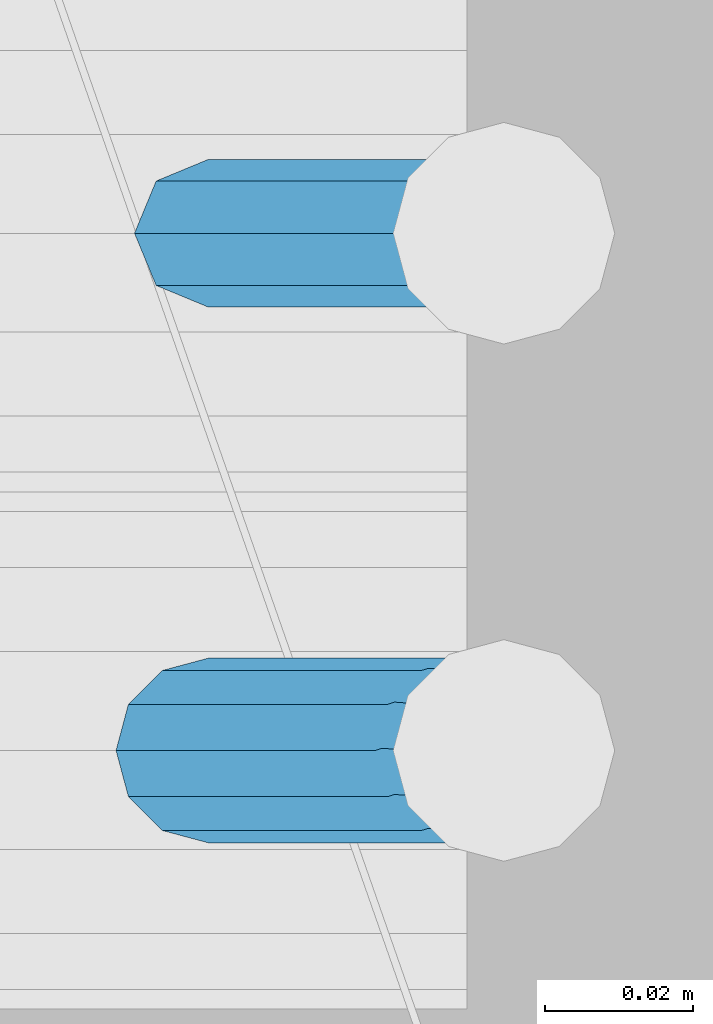
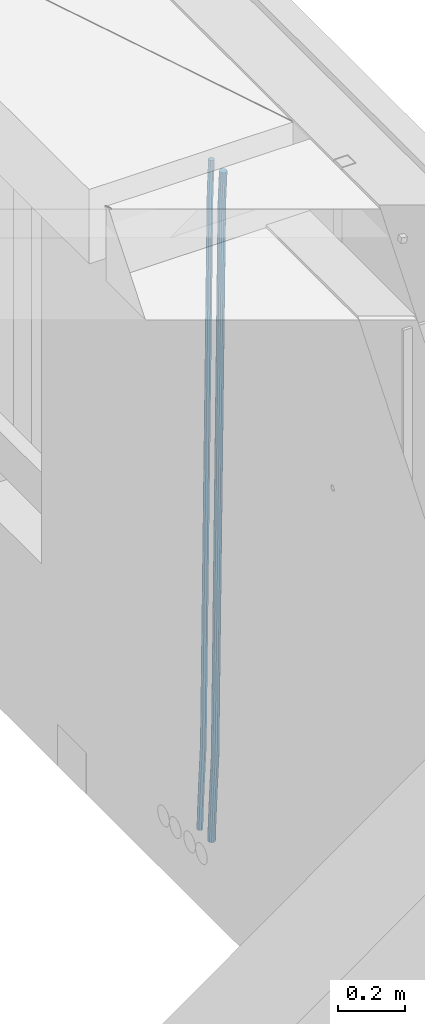
# One storey, part 134 of 350: 2 beams, 1 element without a shape of its own.
"""IFC2X3 building model written with IfcOpenShell, lengths in millimetres."""

from ifc_helpers import new_model, si_unit, frame, origin_with_axes, place, context, subcontext, project, spatial, faceted_brep, material, type_object, element, aggregate, save


model = new_model("IFC2X3")

# Units and contexts
model_context = context("Model", 3, precision=1e-05, world=origin_with_axes())
body_context = subcontext(model_context, "Body", "Model", "MODEL_VIEW")
ifc_project = project(units=[si_unit("LENGTHUNIT", "METRE", prefix="MILLI"), si_unit("AREAUNIT", "SQUARE_METRE"), si_unit("VOLUMEUNIT", "CUBIC_METRE"), si_unit("MASSUNIT", "GRAM", prefix="KILO"), si_unit("TIMEUNIT", "SECOND"), si_unit("PLANEANGLEUNIT", "RADIAN"), si_unit("SOLIDANGLEUNIT", "STERADIAN"), si_unit("THERMODYNAMICTEMPERATUREUNIT", "DEGREE_CELSIUS"), si_unit("LUMINOUSINTENSITYUNIT", "LUMEN")], contexts=[model_context])

# Site, building, storey
site_placement = place(None, origin_with_axes())
site = spatial("IfcSite", under=ifc_project, at=site_placement, CompositionType="ELEMENT")
building_placement = place(site_placement, origin_with_axes())
building = spatial("IfcBuilding", under=site, at=building_placement, CompositionType="ELEMENT")
storey_placement = place(building_placement, origin_with_axes())
storey = spatial("IfcBuildingStorey", under=building, at=storey_placement, Name="2", CompositionType="ELEMENT", Elevation=0.0)

# Assembly, beams
assembly_placement = place(storey_placement, origin_with_axes())
assembly = element("IfcElementAssembly", 1, at=assembly_placement, inside=storey, AssemblyPlace="NOTDEFINED", PredefinedType="REINFORCEMENT_UNIT")
ifc_material = material()
beam_type_1 = type_object("IfcBeamType", Name="D20", PredefinedType="NOTDEFINED")
beam_1_placement = place(assembly_placement, frame((34944.9999977209, 18835.0002441367, 84990.0), z_axis=(0.999642804629538, 0.000205762999925497, -0.0267249099901003), x_axis=(0.0267249109941254, -4.30000210532798e-08, 0.999642825779465)))
beam_1 = element("IfcBeam", 2, at=beam_1_placement, type_object=beam_type_1, material=ifc_material, Name="JM20", ObjectType="D20", context=body_context, shape_type="Brep", body=[
    faceted_brep([(0.0, -10.0, 0.0), (-4.19531716033816e-08, -7.07106781186667, -7.07106781187031), (60.4266690400545, -7.0710677960451, -7.07106780570757), (60.4266690441291, -9.99999998418934, 6.15546014159918e-09), (0.0, 0.0, -10.0), (60.426669036824, 1.58106558956206e-08, -9.99999999384454), (4.196772351861e-08, 7.07106781186303, -7.07106781186667), (60.4266690363438, 7.07106782768096, -7.07106780570757), (0.0, 10.0, 0.0), (60.4266690388904, 10.0000000158179, 6.15182216279209e-09), (4.196772351861e-08, 7.07106781185939, 7.07106781185939), (60.4266690429649, 7.07106782768096, 7.07106781802577), (0.0, 0.0, 10.0), (60.4266690461809, 1.58179318532348e-08, 10.0000000061555), (-4.19531716033816e-08, -7.07106781187031, 7.07106781185939), (60.4266690466611, -7.07106779605238, 7.07106781802213), (61.0378400410118, -7.07106779588503, -7.07106780564936), (60.991799419251, -9.99999998403655, 6.21366780251265e-09), (61.0569027789461, 1.5985278878361e-08, -9.99999999378269), (61.0378209396877, 7.07106782784831, -7.07106780564936), (60.9917724058905, 10.0000000159635, 6.21366780251265e-09), (60.9457317841297, 7.07106782781193, 7.0710678180767), (60.9266690461809, 1.59488990902901e-08, 10.0000000062028), (60.9457508854539, -7.07106779591413, 7.0710678180767), (61.6489592143771, -7.07106614513759, -7.06310863441468), (61.5568818710308, -9.9999984576425, 0.00735959856683621), (61.6870830769039, 1.71821739058942e-06, -9.99179257185824), (61.6489210170112, 7.07106947854481, -7.06310888312146), (61.556827851804, 10.0000015422847, 0.00735924683976918), (61.4647505084577, 7.07106922979438, 7.07782747982128), (61.4266266459163, 1.36643211590126e-06, 10.0065114172685), (61.464788705809, -7.07106639389531, 7.07782772852806), (176.543135720174, -7.07075579406956, -5.56673531796696), (176.451058376813, -9.99968810657447, 1.50373291501455), (176.581259582701, 0.000312069292704109, -8.49541925541052), (176.543097522794, 7.07137982961285, -5.56673556667374), (176.451004357587, 10.00031189336, 1.50373256329476), (176.35892701424, 7.07137958085514, 8.57420079627263), (176.320803151699, 0.000311717507429421, 11.5028847337162), (176.358965211621, -7.07075604281999, 8.57420104497578), (177.098753836006, -7.07075429323595, -5.55949898843028), (176.98362511232, -9.99968666800123, 1.510669025065), (177.146421932586, 0.000313595905026887, -8.48805862247536), (177.098706077581, 7.07138133041735, -5.55949936166144), (176.983557571715, 10.0003133318824, 1.51066849724157), (176.868428848029, 7.07138095712435, 8.58083651073321), (176.820760751449, 0.000313067976094317, 11.5093961447819), (176.868476606425, -7.07075466652896, 8.58083688396073), (177.654312950661, -7.07075204110879, -5.54863964998367), (177.516135294456, -9.99968450931192, 1.52107783331303), (177.711524267797, 0.000315886711177882, -8.47701274570863), (177.654255632195, 7.07138358250813, -5.54864021007961), (177.516054233929, 10.0003154905207, 1.5210770412159), (177.377876577739, 7.0713830223176, 8.59079452451624), (177.320665260588, 0.000315094497636892, 11.5191676202448), (177.377933896176, -7.07075260129932, 8.59079508461218), (299.436796249574, -7.07025836271714, -3.1681962331204), (299.298618593355, -9.99919083092027, 3.90152125031091), (299.494007566798, 0.000809565110102994, -6.09656932889993), (299.436738931283, 7.07187726089978, -3.16819679320906), (299.298537533061, 10.0008091689197, 3.90152045822106), (299.160359876842, 7.07187670072017, 10.9712379416487), (299.103148559603, 0.000808772889286047, 13.8996110374392), (299.160417195119, -7.07025892290039, 10.9712385017483), (299.98743051647, -7.07025613056248, -3.15743315966392), (299.971788958996, -9.99918809853989, 3.91467979818117), (299.993912075952, 0.000811591617093654, -6.08679785393178), (299.987423933868, 7.07187949325817, -3.1574327280432), (299.971753863239, 10.0008119014747, 3.91467990454839), (299.95611230444, 7.07187992653053, 10.9867922621015), (299.949630744944, 0.000812204350950196, 13.9161569563694), (299.956118887014, -7.07025569729012, 10.9867918304735), (300.538107039494, -7.07025785017686, -3.16575821840888), (300.644985195438, -9.99919020432935, 3.90450175465594), (300.493854948218, 0.000810030429420294, -6.09435592770024), (300.538151196495, 7.071877773491, -3.16575855385963), (300.645047642858, 10.0008097955724, 3.90450128024895), (300.751925798773, 7.07187744142357, 10.9747612533101), (300.796177890064, 0.000809560813650023, 13.9033589625978), (300.751881641787, -7.07025818224065, 10.9747615887682), (2293.36490490142, -7.07648090940347, -33.2930642912361), (2293.47178305736, -10.0054132635523, -26.2228043181785), (2293.32065281013, -0.00541302880083094, -36.2216620005347), (2293.36494905842, 7.06565471425711, -33.2930646266868), (2293.47184550477, 9.99458673634581, -26.2228047925819), (2293.57872366071, 7.06565438219332, -19.1525448195243), (2293.62297575199, -0.00541349841296324, -16.2239471102366), (2293.57867950371, -7.0764812414709, -19.1525444840736), (2294.0658245362, -7.07648309818615, -33.3036607065333), (2294.05312277409, -10.0054150789219, -26.2315929392535), (2294.10928714235, -0.00541549149056664, -36.2335844756526), (2294.15805078732, 7.06565223761572, -33.3050546393533), (2294.18355038921, 9.99458451388637, -26.2335642579346), (2294.17084862708, 7.06565253314329, -19.1614964906439), (2294.12738602093, -0.00541507354500936, -16.2315727215355), (2294.07862237596, -7.07648280265857, -19.1601025578348), (2294.76670261032, -7.08562269121467, -33.294332712383), (2294.63442802057, -10.0129954178956, -26.2238563411993), (2294.89787471293, -0.0156988342423574, -36.2230891548279), (2294.95110548967, 7.05531064255774, -33.2944998654275), (2294.89521307347, 9.98530428734011, -26.2240927312887), (2294.76293848372, 7.0579315606592, -19.1536163601049), (2294.63176638114, -0.0119922963167483, -16.2248599176673), (2294.57853560438, -7.08300177311321, -19.1534492070678), (2316.52657204497, -7.36937582653991, -33.0047303660212), (2316.39429745522, -10.2967485532172, -25.9342539948302), (2316.65774414754, -0.299451969567599, -35.9334868084661), (2316.7109749243, 6.7715575072325, -33.0048975190657), (2316.65508250811, 9.70155115201487, -25.9344903849269), (2316.52280791836, 6.7741784253376, -18.8640140137468), (2316.39163581574, -0.295745431634714, -15.9352575713092), (2316.33840503903, -7.36675490843481, -18.863846860706), (2317.16202064224, -7.37766220584308, -32.9962731735213), (2317.05438744847, -10.3053562613532, -25.9254688497131), (2317.23607125619, -0.306993473008333, -35.925789846493), (2317.23316144495, 6.76474808850253, -32.9979477328052), (2317.15499573652, 9.6950321815566, -25.9278370341635), (2317.04736254275, 6.7673381260538, -18.8570327103698), (2316.97331192881, -0.303330606784584, -15.9275160373909), (2316.97622174003, -7.37507216829545, -18.8553581510787), (2317.79752306276, -7.37578610372293, -32.9880110666527), (2317.71453320107, -10.3033876998124, -25.9168792378296), (2317.81444760226, -0.305295583297266, -35.918287695793), (2317.75539265381, 6.76628640723357, -32.9911928173897), (2317.65495180529, 9.69652304524061, -25.9213789128698), (2317.5719619436, 6.76892144914746, -18.8502470840467), (2317.55503740412, -0.301569071270933, -15.9199704549137), (2317.61409235255, -7.3731510618054, -18.847065333317), (2417.8183084176, -7.07752398473531, -31.6906369377139), (2417.73531855589, -10.0051255808248, -24.6195051088798), (2417.83523295709, -0.007033464313281, -34.6209135668432), (2417.77617800863, 7.06454852621755, -31.6938186884508), (2417.67573716014, 9.99478516423187, -24.6240047839383), (2417.59274729842, 7.06718356813872, -17.5528729551006), (2417.57582275895, -0.00330695228694822, -14.6225963259749), (2417.6348777074, -7.07488894281778, -17.5496912043673)], [[[0, 1, 2, 3]], [[1, 4, 5, 2]], [[4, 6, 7, 5]], [[6, 8, 9, 7]], [[8, 10, 11, 9]], [[10, 12, 13, 11]], [[12, 14, 15, 13]], [[14, 0, 3, 15]], [[14, 12, 10, 8, 6, 4, 1, 0]], [[3, 2, 16, 17]], [[2, 5, 18, 16]], [[5, 7, 19, 18]], [[7, 9, 20, 19]], [[9, 11, 21, 20]], [[11, 13, 22, 21]], [[13, 15, 23, 22]], [[15, 3, 17, 23]], [[17, 16, 24, 25]], [[16, 18, 26, 24]], [[18, 19, 27, 26]], [[19, 20, 28, 27]], [[20, 21, 29, 28]], [[21, 22, 30, 29]], [[22, 23, 31, 30]], [[23, 17, 25, 31]], [[25, 24, 32, 33]], [[24, 26, 34, 32]], [[26, 27, 35, 34]], [[27, 28, 36, 35]], [[28, 29, 37, 36]], [[29, 30, 38, 37]], [[30, 31, 39, 38]], [[31, 25, 33, 39]], [[33, 32, 40, 41]], [[32, 34, 42, 40]], [[34, 35, 43, 42]], [[35, 36, 44, 43]], [[36, 37, 45, 44]], [[37, 38, 46, 45]], [[38, 39, 47, 46]], [[39, 33, 41, 47]], [[41, 40, 48, 49]], [[40, 42, 50, 48]], [[42, 43, 51, 50]], [[43, 44, 52, 51]], [[44, 45, 53, 52]], [[45, 46, 54, 53]], [[46, 47, 55, 54]], [[47, 41, 49, 55]], [[49, 48, 56, 57]], [[48, 50, 58, 56]], [[50, 51, 59, 58]], [[51, 52, 60, 59]], [[52, 53, 61, 60]], [[53, 54, 62, 61]], [[54, 55, 63, 62]], [[55, 49, 57, 63]], [[57, 56, 64, 65]], [[56, 58, 66, 64]], [[58, 59, 67, 66]], [[59, 60, 68, 67]], [[60, 61, 69, 68]], [[61, 62, 70, 69]], [[62, 63, 71, 70]], [[63, 57, 65, 71]], [[65, 64, 72, 73]], [[64, 66, 74, 72]], [[66, 67, 75, 74]], [[67, 68, 76, 75]], [[68, 69, 77, 76]], [[69, 70, 78, 77]], [[70, 71, 79, 78]], [[71, 65, 73, 79]], [[73, 72, 80, 81]], [[72, 74, 82, 80]], [[74, 75, 83, 82]], [[75, 76, 84, 83]], [[76, 77, 85, 84]], [[77, 78, 86, 85]], [[78, 79, 87, 86]], [[79, 73, 81, 87]], [[81, 80, 88, 89]], [[80, 82, 90, 88]], [[82, 83, 91, 90]], [[83, 84, 92, 91]], [[84, 85, 93, 92]], [[85, 86, 94, 93]], [[86, 87, 95, 94]], [[87, 81, 89, 95]], [[89, 88, 96, 97]], [[88, 90, 98, 96]], [[90, 91, 99, 98]], [[91, 92, 100, 99]], [[92, 93, 101, 100]], [[93, 94, 102, 101]], [[94, 95, 103, 102]], [[95, 89, 97, 103]], [[97, 96, 104, 105]], [[96, 98, 106, 104]], [[98, 99, 107, 106]], [[99, 100, 108, 107]], [[100, 101, 109, 108]], [[101, 102, 110, 109]], [[102, 103, 111, 110]], [[103, 97, 105, 111]], [[105, 104, 112, 113]], [[104, 106, 114, 112]], [[106, 107, 115, 114]], [[107, 108, 116, 115]], [[108, 109, 117, 116]], [[109, 110, 118, 117]], [[110, 111, 119, 118]], [[111, 105, 113, 119]], [[113, 112, 120, 121]], [[112, 114, 122, 120]], [[114, 115, 123, 122]], [[115, 116, 124, 123]], [[116, 117, 125, 124]], [[117, 118, 126, 125]], [[118, 119, 127, 126]], [[119, 113, 121, 127]], [[121, 120, 128, 129]], [[120, 122, 130, 128]], [[122, 123, 131, 130]], [[123, 124, 132, 131]], [[124, 125, 133, 132]], [[125, 126, 134, 133]], [[126, 127, 135, 134]], [[127, 121, 129, 135]], [[130, 131, 132, 133, 134, 135, 129, 128]]]),
])
beam_type_2 = type_object("IfcBeamType", Name="D25", PredefinedType="NOTDEFINED")
beam_2_placement = place(assembly_placement, frame((34944.9999977209, 18765.0002441367, 84990.0), z_axis=(0.999642804629538, 0.000205762999925497, -0.0267249099901003), x_axis=(0.0267249109941254, -4.30000210532798e-08, 0.999642825779465)))
beam_2 = element("IfcBeam", 3, at=beam_2_placement, type_object=beam_type_2, material=ifc_material, Name="JM25", ObjectType="D25", context=body_context, shape_type="Brep", body=[
    faceted_brep([(-7.41420080885291e-08, -12.5, -3.63797880709171e-12), (-6.42030499875546e-08, -10.8253175473074, -6.25000000000364), (60.4103898235917, -10.8253175318459, -6.2499999938409), (60.4103898269532, -12.4999999845422, 6.16273609921336e-09), (-3.70782800018787e-08, -6.25000000000364, -10.8253175473074), (60.4103898202884, -6.24999998454587, -10.8253175411446), (-1.45519152283669e-11, -3.63797880709171e-12, -12.5), (60.4103898179019, 1.54577719513327e-08, -12.4999999938373), (3.70637280866504e-08, 6.25, -10.8253175473074), (60.410389817087, 6.25000001545777, -10.825317541141), (6.42030499875546e-08, 10.8253175473001, -6.25000000000364), (60.410389818062, 10.8253175627578, -6.24999999383726), (7.41420080885291e-08, 12.4999999999927, 0.0), (60.4103898205503, 12.5000000154541, 6.16273609921336e-09), (6.42176019027829e-08, 10.8253175473001, 6.24999999999636), (60.4103898238973, 10.8253175627651, 6.2500000061591), (3.70928319171071e-08, 6.24999999999636, 10.8253175473037), (60.4103898272151, 6.25000001546141, 10.8253175534664), (1.45519152283669e-11, -3.63797880709171e-12, 12.4999999999964), (60.4103898296162, 1.54541339725256e-08, 12.5000000061591), (-3.7049176171422e-08, -6.25000000000364, 10.8253175473001), (60.4103898304165, -6.24999998454587, 10.8253175534701), (-6.41884980723262e-08, -10.8253175473074, 6.25), (60.4103898294561, -10.8253175318459, 6.25000000616637), (61.0324985728803, -10.8253175316895, -6.24999999377542), (60.991802792938, -12.4999999843931, 6.22458173893392e-09), (61.0622854283865, -6.24999998437852, -10.8253175410755), (61.0731819955545, 1.5628756955266e-08, -12.4999999937718), (61.0622685480339, 6.25000001562512, -10.8253175410791), (61.032469335245, 10.8253175629216, -6.24999999377178), (60.9917690322181, 12.5000000156033, 6.22458173893392e-09), (60.9510732522613, 10.8253175629034, 6.25000000621731), (60.9212863967696, 6.25000001558874, 10.8253175535247), (60.9103898296162, 1.55814632307738e-08, 12.5000000062137), (60.9213032771368, -6.24999998441126, 10.8253175535174), (60.9511024898966, -10.8253175317113, 6.25000000621731), (61.6545545670233, -10.8253158516927, -6.24189838219536), (61.573166454793, -12.499998414296, 0.00757164385504439), (61.7141257553885, -6.24999822394238, -10.8168280205282), (61.7359179680789, 1.80548886419274e-06, -12.491368569139), (61.7140919992817, 6.25000177601396, -10.8168282403167), (61.6544960997562, 10.8253192428383, -6.2418987628771), (61.5730989426083, 12.5000015856094, 0.0075712042817031), (61.4917108303925, 10.8253190230062, 6.25704123032847), (61.4321396420273, 6.25000139525582, 10.8319708686649), (61.4103474293224, 1.36582457344048e-06, 12.5065114172721), (61.4321733981196, -6.24999860470052, 10.8319710884571), (61.4917692976451, -10.8253160715249, 6.25704161101385), (176.524302641745, -10.8250056210964, -4.74584321979273), (176.442914529529, -12.4996881836996, 1.50362680625403), (176.583873830095, -6.24968799334965, -9.3207728581292), (176.605666042786, 0.000312036081595579, -10.9953134067364), (176.583840074018, 6.25031200660669, -9.32077307791769), (176.524244174492, 10.8256294734347, -4.74584360047811), (176.44284701733, 12.5003118162058, 1.50362636668069), (176.361458905099, 10.8256292535989, 7.75309639272746), (176.301887716749, 6.25031162585219, 12.3280260310676), (176.280095504058, 0.000311596420942806, 14.0025665796711), (176.301921472827, -6.24968837410415, 12.3280262508561), (176.361517372367, -10.8250058409321, 7.75309677341284), (177.085397012124, -10.8250041057399, -4.73853556792164), (176.983633547483, -12.4996867233749, 1.51066909103247), (177.159881729676, -6.24968643771717, -9.31327097355097), (177.187129580227, 0.000313606451527448, -10.987740468332), (177.159839524218, 6.25031356221734, -9.31327130338468), (177.085323910098, 10.8256309887511, -4.73853613920801), (176.983549136537, 12.5003132764905, 1.51066843136869), (176.881785671867, 10.8256306588555, 7.7598730903228), (176.80730095433, 6.25031299082912, 12.3346084959521), (176.780053103794, 0.000312946667690994, 14.0090779907332), (176.807343159802, -6.2496870091054, 12.3346088257895), (176.881858773908, -10.8250044356355, 7.7598736616128), (177.646431799818, -10.8250018318176, -4.72756919822132), (177.524295146417, -12.4996845320202, 1.52123723245313), (177.735828462886, -6.24968410334986, -9.30201312475765), (177.768531371941, 0.00031596292683389, -10.9763759912421), (177.735777808921, 6.25031589654827, -9.30201361973741), (177.646344064575, 10.8256332626152, -4.72757005553649), (177.524193838486, 12.5003154677688, 1.52123624250817), (177.402057185071, 10.8256327675663, 7.77004267317898), (177.312660521988, 6.2503150390985, 12.3444865997226), (177.279957612933, 0.00031497282179771, 14.0188494661961), (177.312711175953, -6.24968496079964, 12.3444870946951), (177.402144920314, -10.8250023268702, 7.77004353049415), (299.377443161706, -10.8245084454466, -2.34813158632096), (299.255306508276, -12.4991911456491, 3.90067484435349), (299.466839824803, -6.24919071697514, -6.92257551286093), (299.499542733873, 0.0008093492979242, -8.59693837933446), (299.466789170867, 6.250809282923, -6.92257600783341), (299.377355426492, 10.8261266489935, -2.34813244364341), (299.255205200388, 12.5008088541435, 3.90067385440125), (299.133068546944, 10.826126153941, 10.1494802850757), (299.043671883861, 6.25080842546959, 14.7239242116229), (299.010968974762, 0.000808359200163977, 16.3982870780892), (299.043722537797, -6.24919157442127, 14.7239247065918), (299.133156282158, -10.8245089404954, 10.1494811423981), (299.98561436501, -10.8245059804758, -2.33624385599614), (299.97179243555, -12.4991882411778, 3.91467976726199), (299.995742293278, -6.24918857328521, -6.91223722345239), (299.999447243041, 0.000811375455668895, -8.58716690387519), (299.995736475976, 6.25081142679483, -6.91223684201032), (299.985604289133, 10.8261291142808, -2.33624319533556), (299.971750386685, 12.5008117588586, 3.91467993563856), (299.957928457196, 10.8261294971744, 10.1656035610831), (299.947800528913, 6.25081208998381, 14.7415969285394), (299.944095579151, 0.00081214124293183, 16.4165266089549), (299.947806346216, -6.24918791008895, 14.7415965471009), (299.957938533058, -10.8245055975785, 10.1656029004225), (300.593832239858, -10.8245078794353, -2.34543881707941), (300.688302931099, -12.4991904788549, 3.90384712594823), (300.524685350189, -6.24919022474205, -6.92023371784308), (300.499390115292, 0.000809814544481924, -8.59472497713432), (300.524724372954, 6.25080977519247, -6.92023401429469), (300.593899829313, 10.8261272150703, -2.34543933054374), (300.688380976673, 12.5008095210287, 3.90384653304136), (300.782851667915, 10.8261269216127, 10.1531324760799), (300.851998557599, 6.25080926691589, 14.7279273768363), (300.877293792495, 0.000809227632998955, 16.4024186361276), (300.851959534804, -6.24919073302226, 14.7279276732806), (300.782784078474, -10.8245081728965, 10.153132989537), (2293.32930409742, -10.8307295605009, -32.4713622331001), (2293.42377478865, -12.5054121599169, -26.2220762900724), (2293.26015720774, -6.2554119058077, -37.0461571338565), (2293.23486197284, -0.00541186651753378, -38.7206483931477), (2293.26019623051, 6.24458809413409, -37.0461574303008), (2293.32937168686, 10.8199055340046, -32.4713627465644), (2293.42385283421, 12.4945878399631, -26.2220768829684), (2293.51832352545, 10.8199052405434, -19.972790939948), (2293.58747041514, 6.24458758585388, -15.3979960391844), (2293.61276565003, -0.00541245343265473, -13.7235047798931), (2293.58743139236, -6.25541241408428, -15.3979957427327), (2293.51825593603, -10.8307298539585, -19.9727904264691), (2294.0420846676, -10.8307317859326, -32.4821379598216), (2294.03681932652, -12.5054140739521, -26.2313442200393), (2294.06778164886, -6.2554144273563, -37.0583666982457), (2294.10702478497, -0.00541458957013674, -38.7338336404937), (2294.14929890928, 6.24458531819619, -37.0595987724118), (2294.18327670435, 10.8199028679592, -32.4842719748667), (2294.1998538474, 12.4945854171456, -26.2338083683717), (2294.19458850632, 10.819903129126, -19.9830146285858), (2294.16889152506, 6.24458577054975, -15.4067858901581), (2294.12964838895, -0.0054140672327776, -13.7313189479173), (2294.08737426462, -6.2554139749991, -15.4055538159919), (2294.05339646956, -10.8307315247621, -19.9808806135297), (2294.75482297382, -10.84002603931, -32.4726521173216), (2294.64982751427, -12.513407826169, -26.2231856868602), (2294.87535820232, -6.26594539088183, -37.0476186524102), (2294.97913588268, -0.0167870967634371, -38.7222267036377), (2295.0383488692, 6.23299192477134, -37.0477663960555), (2295.03713108998, 10.8087684320271, -32.4729080168181), (2294.97580884799, 12.4844668051373, -26.2234811741473), (2294.87081338844, 10.8110850182784, -19.9740147436787), (2294.7502781599, 6.23700436985018, -15.3990482086047), (2294.64650047956, -0.0121539242718427, -13.7244401573698), (2294.58728749304, -6.26193294580662, -15.3989004649666), (2294.58850527227, -10.8377094530588, -19.9737588441894), (2316.44667268227, -11.1228921988077, -32.1839550346631), (2316.34167722271, -12.7962739856739, -25.9344886042054), (2316.56720791078, -6.54881155039038, -36.7589215697517), (2316.67098559113, -0.299653256264719, -38.4335296209792), (2316.73019857766, 5.95012576527006, -36.759069313397), (2316.72898079845, 10.5259022725259, -32.1842109341669), (2316.66765855643, 12.2016006456361, -25.9347840914961), (2316.56266309689, 10.5282188587698, -19.6853176610275), (2316.44212786836, 5.95413821035254, -15.1103511259389), (2316.33835018802, -0.295020083769487, -13.4357430747186), (2316.27913720149, -6.54479910530426, -15.1102033823008), (2316.28035498071, -11.1205756125637, -19.685061761531), (2317.13234804722, -11.1318335458927, -32.1748293731798), (2317.04181141085, -12.8054038787741, -25.9251705100723), (2317.2154741603, -6.5572650749491, -36.7502937866229), (2317.26891617525, -0.307450393454928, -38.4255717558117), (2317.27835434731, 5.94297770185585, -36.7517739018112), (2317.24125972588, 10.5192220504723, -32.1773930078925), (2317.16757178486, 12.1950816748285, -25.9281307404563), (2317.0770351485, 10.5215113419545, -19.6784718773561), (2316.99390903539, 5.94694287101083, -15.1030074639057), (2316.94046702047, -0.302871810494253, -13.4277294947169), (2316.9310288484, -6.55329990579412, -15.1015273487101), (2316.96812346982, -11.1295442544142, -19.6759082426288), (2317.81808136747, -11.1298054502913, -32.1659056455355), (2317.74200467508, -12.803315894289, -25.9160547315114), (2317.86379538118, -6.55536082026447, -36.7418676070083), (2317.8668976831, -0.305700748642266, -38.417815303761), (2317.82655701396, 5.94458339541234, -36.7446799039099), (2317.75358262347, 10.5207330230332, -32.1707766866384), (2317.66752794063, 12.1965725370646, -25.9216793252963), (2317.59145124823, 10.5230620930706, -19.6718284112721), (2317.54573723453, 5.94861746304377, -15.0958664497994), (2317.54263493262, -0.301042608574789, -13.4199187530394), (2317.58297560175, -6.55132675263303, -15.0930541529051), (2317.65594999224, -11.1274763802539, -19.6669573701693), (2417.81884292323, -10.831603083323, -30.8687911350135), (2417.74276623082, -12.505113527317, -24.618940220982), (2417.86455693691, -6.25715845329614, -35.4447530964935), (2417.86765923884, -0.00749838167394046, -37.1207007932499), (2417.82731856969, 6.24278576237703, -35.4475653933878), (2417.75434417921, 10.8189353900088, -30.8736621761236), (2417.66828949639, 12.494774904033, -24.6245648147851), (2417.59221280397, 10.8212644600353, -18.3747139007501), (2417.54649879028, 6.2468198300121, -13.79875193927), (2417.54339648837, -0.00284024161010166, -12.1228042425173), (2417.5837371575, -6.25312438566107, -13.795939642383), (2417.65671154798, -10.8292740132893, -18.3698428596399)], [[[0, 1, 2, 3]], [[1, 4, 5, 2]], [[4, 6, 7, 5]], [[6, 8, 9, 7]], [[8, 10, 11, 9]], [[10, 12, 13, 11]], [[12, 14, 15, 13]], [[14, 16, 17, 15]], [[16, 18, 19, 17]], [[18, 20, 21, 19]], [[20, 22, 23, 21]], [[22, 0, 3, 23]], [[22, 20, 18, 16, 14, 12, 10, 8, 6, 4, 1, 0]], [[3, 2, 24, 25]], [[2, 5, 26, 24]], [[5, 7, 27, 26]], [[7, 9, 28, 27]], [[9, 11, 29, 28]], [[11, 13, 30, 29]], [[13, 15, 31, 30]], [[15, 17, 32, 31]], [[17, 19, 33, 32]], [[19, 21, 34, 33]], [[21, 23, 35, 34]], [[23, 3, 25, 35]], [[25, 24, 36, 37]], [[24, 26, 38, 36]], [[26, 27, 39, 38]], [[27, 28, 40, 39]], [[28, 29, 41, 40]], [[29, 30, 42, 41]], [[30, 31, 43, 42]], [[31, 32, 44, 43]], [[32, 33, 45, 44]], [[33, 34, 46, 45]], [[34, 35, 47, 46]], [[35, 25, 37, 47]], [[37, 36, 48, 49]], [[36, 38, 50, 48]], [[38, 39, 51, 50]], [[39, 40, 52, 51]], [[40, 41, 53, 52]], [[41, 42, 54, 53]], [[42, 43, 55, 54]], [[43, 44, 56, 55]], [[44, 45, 57, 56]], [[45, 46, 58, 57]], [[46, 47, 59, 58]], [[47, 37, 49, 59]], [[49, 48, 60, 61]], [[48, 50, 62, 60]], [[50, 51, 63, 62]], [[51, 52, 64, 63]], [[52, 53, 65, 64]], [[53, 54, 66, 65]], [[54, 55, 67, 66]], [[55, 56, 68, 67]], [[56, 57, 69, 68]], [[57, 58, 70, 69]], [[58, 59, 71, 70]], [[59, 49, 61, 71]], [[61, 60, 72, 73]], [[60, 62, 74, 72]], [[62, 63, 75, 74]], [[63, 64, 76, 75]], [[64, 65, 77, 76]], [[65, 66, 78, 77]], [[66, 67, 79, 78]], [[67, 68, 80, 79]], [[68, 69, 81, 80]], [[69, 70, 82, 81]], [[70, 71, 83, 82]], [[71, 61, 73, 83]], [[73, 72, 84, 85]], [[72, 74, 86, 84]], [[74, 75, 87, 86]], [[75, 76, 88, 87]], [[76, 77, 89, 88]], [[77, 78, 90, 89]], [[78, 79, 91, 90]], [[79, 80, 92, 91]], [[80, 81, 93, 92]], [[81, 82, 94, 93]], [[82, 83, 95, 94]], [[83, 73, 85, 95]], [[85, 84, 96, 97]], [[84, 86, 98, 96]], [[86, 87, 99, 98]], [[87, 88, 100, 99]], [[88, 89, 101, 100]], [[89, 90, 102, 101]], [[90, 91, 103, 102]], [[91, 92, 104, 103]], [[92, 93, 105, 104]], [[93, 94, 106, 105]], [[94, 95, 107, 106]], [[95, 85, 97, 107]], [[97, 96, 108, 109]], [[96, 98, 110, 108]], [[98, 99, 111, 110]], [[99, 100, 112, 111]], [[100, 101, 113, 112]], [[101, 102, 114, 113]], [[102, 103, 115, 114]], [[103, 104, 116, 115]], [[104, 105, 117, 116]], [[105, 106, 118, 117]], [[106, 107, 119, 118]], [[107, 97, 109, 119]], [[109, 108, 120, 121]], [[108, 110, 122, 120]], [[110, 111, 123, 122]], [[111, 112, 124, 123]], [[112, 113, 125, 124]], [[113, 114, 126, 125]], [[114, 115, 127, 126]], [[115, 116, 128, 127]], [[116, 117, 129, 128]], [[117, 118, 130, 129]], [[118, 119, 131, 130]], [[119, 109, 121, 131]], [[121, 120, 132, 133]], [[120, 122, 134, 132]], [[122, 123, 135, 134]], [[123, 124, 136, 135]], [[124, 125, 137, 136]], [[125, 126, 138, 137]], [[126, 127, 139, 138]], [[127, 128, 140, 139]], [[128, 129, 141, 140]], [[129, 130, 142, 141]], [[130, 131, 143, 142]], [[131, 121, 133, 143]], [[133, 132, 144, 145]], [[132, 134, 146, 144]], [[134, 135, 147, 146]], [[135, 136, 148, 147]], [[136, 137, 149, 148]], [[137, 138, 150, 149]], [[138, 139, 151, 150]], [[139, 140, 152, 151]], [[140, 141, 153, 152]], [[141, 142, 154, 153]], [[142, 143, 155, 154]], [[143, 133, 145, 155]], [[145, 144, 156, 157]], [[144, 146, 158, 156]], [[146, 147, 159, 158]], [[147, 148, 160, 159]], [[148, 149, 161, 160]], [[149, 150, 162, 161]], [[150, 151, 163, 162]], [[151, 152, 164, 163]], [[152, 153, 165, 164]], [[153, 154, 166, 165]], [[154, 155, 167, 166]], [[155, 145, 157, 167]], [[157, 156, 168, 169]], [[156, 158, 170, 168]], [[158, 159, 171, 170]], [[159, 160, 172, 171]], [[160, 161, 173, 172]], [[161, 162, 174, 173]], [[162, 163, 175, 174]], [[163, 164, 176, 175]], [[164, 165, 177, 176]], [[165, 166, 178, 177]], [[166, 167, 179, 178]], [[167, 157, 169, 179]], [[169, 168, 180, 181]], [[168, 170, 182, 180]], [[170, 171, 183, 182]], [[171, 172, 184, 183]], [[172, 173, 185, 184]], [[173, 174, 186, 185]], [[174, 175, 187, 186]], [[175, 176, 188, 187]], [[176, 177, 189, 188]], [[177, 178, 190, 189]], [[178, 179, 191, 190]], [[179, 169, 181, 191]], [[181, 180, 192, 193]], [[180, 182, 194, 192]], [[182, 183, 195, 194]], [[183, 184, 196, 195]], [[184, 185, 197, 196]], [[185, 186, 198, 197]], [[186, 187, 199, 198]], [[187, 188, 200, 199]], [[188, 189, 201, 200]], [[189, 190, 202, 201]], [[190, 191, 203, 202]], [[191, 181, 193, 203]], [[194, 195, 196, 197, 198, 199, 200, 201, 202, 203, 193, 192]]]),
])
aggregate(assembly, [beam_1, beam_2])

save(model, "model.ifc")
